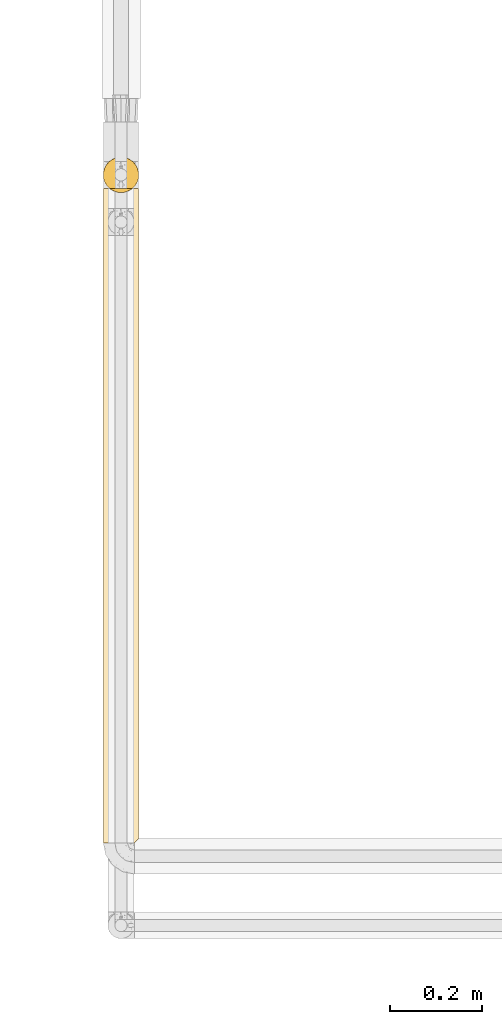
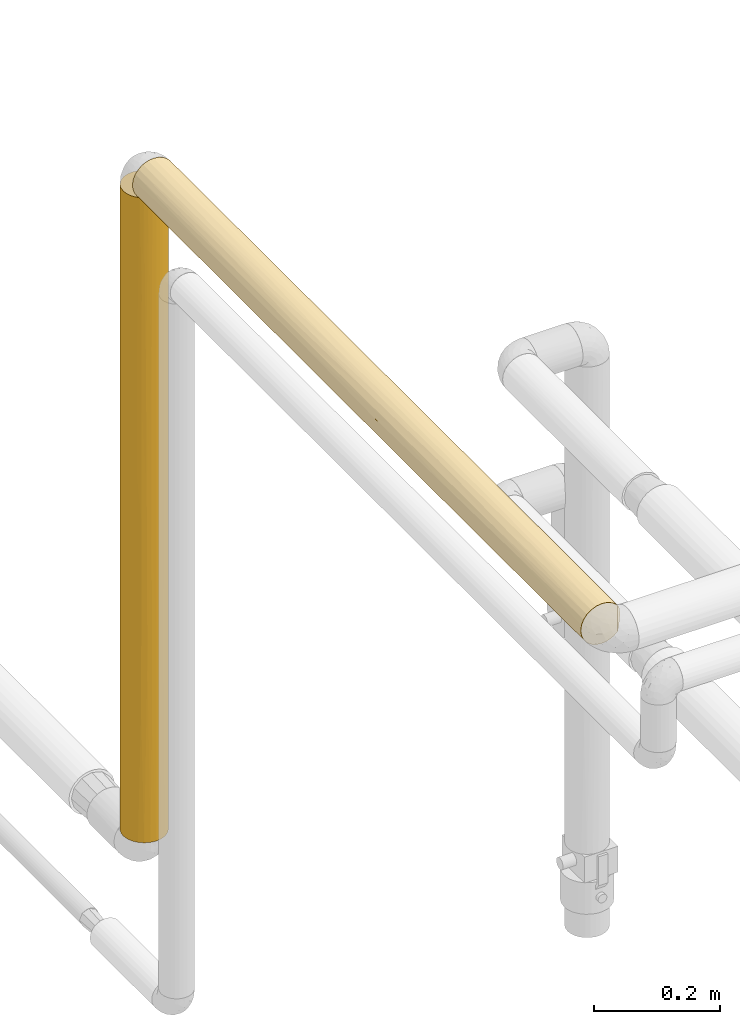
# One storey, part 23 of 827: 2 coverings.
"""IFC2X3 building model written with IfcOpenShell, lengths in millimetres."""

import ifcopenshell
import ifcopenshell.guid

model = None  # the IFC model being written
_history = None  # IfcOwnerHistory: only IFC2X3 demands one
_inside = {}  # id of a spatial element -> (the spatial element, [elements in it])
_under = {}  # id of a project, library or spatial element -> (it, [spatial elements below it])
_declared = {}  # id of a project -> (the project, [libraries it declares])
_typed = {}  # id of a type object -> (the type object, [elements of that type])
_made_of = {}  # id of a material, layer set ... -> (it, [elements and type objects made of it])


def new_model(schema):
    """Start an empty IFC model of exactly this schema.

    Asked for "IFC4X3", IfcOpenShell would pick the latest addendum, in which some entities
    have other attributes; the version numbers below select the first issue.
    IFC2X3 requires an IfcOwnerHistory on every rooted entity: one is made here for all.
    """
    global model, _history
    if schema == "IFC4X3":
        model = ifcopenshell.file(schema_version=(4, 3, 0, 0))
    else:
        model = ifcopenshell.file(schema=schema)
    _inside.clear()
    _under.clear()
    _declared.clear()
    _typed.clear()
    _made_of.clear()
    _history = None
    if model.schema == "IFC2X3":
        org = make("IfcOrganization", Name="unknown")
        user = make(
            "IfcPersonAndOrganization",
            ThePerson=make("IfcPerson", FamilyName="unknown"),
            TheOrganization=org,
        )
        app = make(
            "IfcApplication",
            ApplicationDeveloper=org,
            Version="unknown",
            ApplicationFullName="unknown",
            ApplicationIdentifier="unknown",
        )
        _history = make(
            "IfcOwnerHistory",
            OwningUser=user,
            OwningApplication=app,
            ChangeAction="ADDED",
            CreationDate=0,
        )
    return model


def make(cls, **values):
    """One entity of the class cls with the attributes given. An attribute that is None is left unset."""
    return model.create_entity(
        cls, **{name: value for name, value in values.items() if value is not None}
    )


def entity(cls, *values):
    """Any entity or typed value of the class cls, its attributes in the order of the schema. None: left unset."""
    e = model.create_entity(cls)
    for i, value in enumerate(values):
        if value is not None:
            e[i] = value
    return e


def rooted(cls, **values):
    """An entity with a GlobalId (a new one), such as an element, a storey or a relation."""
    return make(cls, GlobalId=ifcopenshell.guid.new(), OwnerHistory=_history, **values)


def si_unit(unit_type, name, prefix=None):
    """IfcSIUnit, for example si_unit("LENGTHUNIT", "METRE", prefix="MILLI")."""
    return make("IfcSIUnit", UnitType=unit_type, Prefix=prefix, Name=name)


def converted_unit(unit_type, name, factor, base, dimensions=None, offset=None):
    """IfcConversionBasedUnit, such as the inch: factor (a typed value) times the base unit."""
    return make(
        "IfcConversionBasedUnit"
        if offset is None
        else "IfcConversionBasedUnitWithOffset",
        ConversionOffset=offset,
        Dimensions=None
        if dimensions is None
        else entity("IfcDimensionalExponents", *dimensions),
        UnitType=unit_type,
        Name=name,
        ConversionFactor=make(
            "IfcMeasureWithUnit", ValueComponent=factor, UnitComponent=base
        ),
    )


def derived_unit(unit_type, elements):
    """IfcDerivedUnit: a product of units, each with its exponent."""
    return make(
        "IfcDerivedUnit",
        Elements=[
            make("IfcDerivedUnitElement", Unit=unit, Exponent=power)
            for unit, power in elements
        ],
        UnitType=unit_type,
    )


def assignment(units):
    """IfcUnitAssignment: the units of a project."""
    return None if units is None else make("IfcUnitAssignment", Units=units)


def point(xyz):
    """IfcCartesianPoint."""
    return None if xyz is None else make("IfcCartesianPoint", Coordinates=xyz)


def direction(xyz):
    """IfcDirection."""
    return None if xyz is None else make("IfcDirection", DirectionRatios=xyz)


def frame(location, z_axis=None, x_axis=None):
    """IfcAxis2Placement3D, a coordinate frame: its origin and axes. An axis left out is left unset."""
    return make(
        "IfcAxis2Placement3D",
        Location=point(location),
        Axis=direction(z_axis),
        RefDirection=direction(x_axis),
    )


def origin():
    """The frame at (0, 0, 0) with its axes left unset."""
    return frame((0.0, 0.0, 0.0))


def place(relative_to, where):
    """IfcLocalPlacement: puts the frame where relative to a parent placement (None: the world)."""
    return make(
        "IfcLocalPlacement", PlacementRelTo=relative_to, RelativePlacement=where
    )


def context(
    kind, dimensions, precision=None, world=None, true_north=None, identifier=None
):
    """IfcGeometricRepresentationContext, for example the 3D "Model" context."""
    return make(
        "IfcGeometricRepresentationContext",
        ContextIdentifier=identifier,
        ContextType=kind,
        CoordinateSpaceDimension=dimensions,
        Precision=precision,
        WorldCoordinateSystem=world,
        TrueNorth=true_north,
    )


def subcontext(parent, identifier, kind, view, scale=None):
    """IfcGeometricRepresentationSubContext, for example "Body" below "Model"."""
    return make(
        "IfcGeometricRepresentationSubContext",
        ContextIdentifier=identifier,
        ContextType=kind,
        ParentContext=parent,
        TargetScale=scale,
        TargetView=view,
    )


def project(units=None, contexts=None):
    """IfcProject with its units and contexts."""
    return rooted(
        "IfcProject",
        Name="project",
        RepresentationContexts=contexts,
        UnitsInContext=assignment(units),
    )


def spatial(cls, under=None, at=None, **own):
    """A site, building, storey or space (cls), placed at a placement, below another one or the project."""
    s = rooted(cls, ObjectPlacement=at, **own)
    if under is not None:
        _under.setdefault(under.id(), (under, []))[1].append(s)
    return s


def faces_of(points, faces, orient=None, outer=None):
    """IfcFace entities. A face is a list of loops; a loop is a list of indices into points, from 0.

    orient and outer hold one flag for each loop. By default every Orientation is true, the
    first loop of a face is its IfcFaceOuterBound and the others are IfcFaceBound.
    """
    made = []
    for i, loops in enumerate(faces):
        bounds = []
        for j, loop in enumerate(loops):
            is_outer = j == 0 if outer is None else outer[i][j]
            bounds.append(
                make(
                    "IfcFaceOuterBound" if is_outer else "IfcFaceBound",
                    Bound=make("IfcPolyLoop", Polygon=[points[k] for k in loop]),
                    Orientation=True if orient is None else orient[i][j],
                )
            )
        made.append(make("IfcFace", Bounds=bounds))
    return made


def faceted_brep(points, faces, orient=None, outer=None, voids=None):
    """IfcFacetedBrep: a solid bounded by flat faces; with voids (closed shells), ...WithVoids."""
    shared = [point(p) for p in points]
    hull = make("IfcClosedShell", CfsFaces=faces_of(shared, faces, orient, outer))
    if voids is None:
        return make("IfcFacetedBrep", Outer=hull)
    return make(
        "IfcFacetedBrepWithVoids",
        Outer=hull,
        Voids=[
            make(cls, CfsFaces=faces_of(shared, fs, o, b)) for cls, fs, o, b in voids
        ],
    )


def shape(context_of_items, identifier, shape_type, items):
    """IfcShapeRepresentation: the items that make up one representation, for example the "Body"."""
    return make(
        "IfcShapeRepresentation",
        ContextOfItems=context_of_items,
        RepresentationIdentifier=identifier,
        RepresentationType=shape_type,
        Items=items,
    )


def made_of(thing, what):
    """Note that an element or type object is made of a material, layer set ...; save() writes the relation."""
    if what is not None:
        _made_of.setdefault(what.id(), (what, []))[1].append(thing)
    return thing


def element(
    cls,
    number,
    at=None,
    inside=None,
    cuts=None,
    type_object=None,
    material=None,
    context=None,
    identifier="Body",
    shape_type=None,
    held_by="IfcProductDefinitionShape",
    body=None,
    shapes=None,
    **own,
):
    """One element of the class cls, such as IfcWall. Its Tag is "e" and its number.

    at: its placement. inside: the storey or other place that contains it. cuts: it is an
    opening in that element (IfcRelVoidsElement). A single representation is given by context,
    identifier, shape_type and body (its items); several are given by shapes. held_by: the class
    of the entity that holds the representations. save() writes the other relations.
    """
    e = rooted(cls, Tag="e%d" % number, ObjectPlacement=at, **own)
    if body is not None:
        shapes = [shape(context, identifier, shape_type, body)]
    if shapes is not None:
        e.Representation = make(held_by, Representations=shapes)
    if inside is not None:
        _inside.setdefault(inside.id(), (inside, []))[1].append(e)
    if cuts is not None:
        rooted(
            "IfcRelVoidsElement", RelatingBuildingElement=cuts, RelatedOpeningElement=e
        )
    if type_object is not None:
        _typed.setdefault(type_object.id(), (type_object, []))[1].append(e)
    return made_of(e, material)


def aggregate(whole, parts):
    """IfcRelAggregates: a whole, such as a stair, and the parts it consists of."""
    return rooted("IfcRelAggregates", RelatingObject=whole, RelatedObjects=parts)


def save(model, path):
    """Write the relations noted so far, then the file.

    IfcRelAggregates (storeys below a building ...), IfcRelContainedInSpatialStructure (elements
    in a storey), IfcRelDefinesByType, IfcRelAssociatesMaterial and IfcRelDeclares: one each for
    every whole, place, type object, material and project.
    """
    for whole, parts in _under.values():
        aggregate(whole, parts)
    for where, things in _inside.values():
        rooted(
            "IfcRelContainedInSpatialStructure",
            RelatedElements=things,
            RelatingStructure=where,
        )
    for kind, things in _typed.values():
        rooted("IfcRelDefinesByType", RelatedObjects=things, RelatingType=kind)
    for what, things in _made_of.values():
        rooted("IfcRelAssociatesMaterial", RelatedObjects=things, RelatingMaterial=what)
    for by, libraries in _declared.values():
        rooted("IfcRelDeclares", RelatingContext=by, RelatedDefinitions=libraries)
    model.write(path)


model = new_model("IFC2X3")

# Units and contexts
model_context = context("Model", 3, precision=0.01, world=origin(), true_north=direction((6.12303176911189e-17, 1.0)))
body_context = subcontext(model_context, "Body", "Model", "MODEL_VIEW")
ifc_project = project(units=[si_unit("LENGTHUNIT", "METRE", prefix="MILLI"), si_unit("AREAUNIT", "SQUARE_METRE"), si_unit("VOLUMEUNIT", "CUBIC_METRE"), converted_unit("PLANEANGLEUNIT", "DEGREE", entity("IfcRatioMeasure", 0.0174532925199433), si_unit("PLANEANGLEUNIT", "RADIAN"), dimensions=[0, 0, 0, 0, 0, 0, 0]), si_unit("MASSUNIT", "GRAM", prefix="KILO"), derived_unit("MASSDENSITYUNIT", [(si_unit("MASSUNIT", "GRAM", prefix="KILO"), 1), (si_unit("LENGTHUNIT", "METRE"), -3)]), derived_unit("MOMENTOFINERTIAUNIT", [(si_unit("LENGTHUNIT", "METRE"), 4)]), si_unit("TIMEUNIT", "SECOND"), si_unit("FREQUENCYUNIT", "HERTZ"), si_unit("THERMODYNAMICTEMPERATUREUNIT", "DEGREE_CELSIUS"), derived_unit("THERMALTRANSMITTANCEUNIT", [(si_unit("MASSUNIT", "GRAM", prefix="KILO"), 1), (si_unit("THERMODYNAMICTEMPERATUREUNIT", "KELVIN"), -1), (si_unit("TIMEUNIT", "SECOND"), -3)]), derived_unit("VOLUMETRICFLOWRATEUNIT", [(si_unit("LENGTHUNIT", "METRE"), 3), (si_unit("TIMEUNIT", "SECOND"), -1)]), derived_unit("MASSFLOWRATEUNIT", [(si_unit("MASSUNIT", "GRAM", prefix="KILO"), 1), (si_unit("TIMEUNIT", "SECOND"), -1)]), derived_unit("ROTATIONALFREQUENCYUNIT", [(si_unit("TIMEUNIT", "SECOND"), -1)]), si_unit("ELECTRICCURRENTUNIT", "AMPERE"), si_unit("ELECTRICVOLTAGEUNIT", "VOLT"), si_unit("POWERUNIT", "WATT"), si_unit("FORCEUNIT", "NEWTON", prefix="KILO"), si_unit("ILLUMINANCEUNIT", "LUX"), si_unit("LUMINOUSFLUXUNIT", "LUMEN"), si_unit("LUMINOUSINTENSITYUNIT", "CANDELA"), derived_unit("USERDEFINED", [(si_unit("MASSUNIT", "GRAM", prefix="KILO"), -1), (si_unit("LENGTHUNIT", "METRE"), -2), (si_unit("TIMEUNIT", "SECOND"), 3), (si_unit("LUMINOUSFLUXUNIT", "LUMEN"), 1)]), derived_unit("LINEARVELOCITYUNIT", [(si_unit("LENGTHUNIT", "METRE"), 1), (si_unit("TIMEUNIT", "SECOND"), -1)]), si_unit("PRESSUREUNIT", "PASCAL"), derived_unit("USERDEFINED", [(si_unit("LENGTHUNIT", "METRE"), -2), (si_unit("MASSUNIT", "GRAM", prefix="KILO"), 1), (si_unit("TIMEUNIT", "SECOND"), -2)]), derived_unit("LINEARFORCEUNIT", [(si_unit("MASSUNIT", "GRAM", prefix="KILO"), 1), (si_unit("LENGTHUNIT", "METRE"), 1), (si_unit("TIMEUNIT", "SECOND"), -2), (si_unit("LENGTHUNIT", "METRE"), -1)]), derived_unit("PLANARFORCEUNIT", [(si_unit("MASSUNIT", "GRAM", prefix="KILO"), 1), (si_unit("LENGTHUNIT", "METRE"), 1), (si_unit("TIMEUNIT", "SECOND"), -2), (si_unit("LENGTHUNIT", "METRE"), -2)])], contexts=[model_context])

# Site, building, storey
site_placement = place(None, origin())
site = spatial("IfcSite", under=ifc_project, at=site_placement, CompositionType="ELEMENT")
building_placement = place(site_placement, origin())
building = spatial("IfcBuilding", under=site, at=building_placement, CompositionType="ELEMENT")
storey_placement = place(building_placement, frame((0.0, 0.0, 28200.0)))
storey = spatial("IfcBuildingStorey", under=building, at=storey_placement, Name="08", CompositionType="ELEMENT", Elevation=28200.0)

# Coverings
covering_1_placement = place(storey_placement, frame((11891.91, 11180.3, 1573.25)))
element("IfcCovering", 1, at=covering_1_placement, inside=storey, Name=":ADSK_", ObjectType=":ADSK_", PredefinedType="INSULATION", context=body_context, shape_type="Brep", body=[
    faceted_brep([(74.9, 23.98, 1247.65), (77.51, 31.79, 1247.65), (78.4, 40.0, 1247.65), (77.09, 49.93, 1247.65), (73.25, 59.2, 1247.65), (67.15, 67.15, 1247.65), (59.2, 73.25, 1247.65), (49.93, 77.09, 1247.65), (40.0, 78.4, 1247.65), (30.06, 77.09, 1247.65), (20.8, 73.25, 1247.65), (12.84, 67.15, 1247.65), (6.74, 59.2, 1247.65), (2.9, 49.93, 1247.65), (1.6, 40.0, 1247.65), (2.48, 31.79, 1247.65), (5.09, 23.98, 1247.65), (9.31, 16.91, 1247.65), (14.94, 10.9, 1247.65), (65.05, 10.9, 1247.65), (70.68, 16.91, 1247.65), (78.4, 40.0, 1.6), (77.09, 30.06, 1.6), (73.25, 20.8, 1.6), (67.15, 12.84, 1.6), (59.2, 6.74, 1.6), (49.94, 2.9, 1.6), (40.0, 1.6, 1.6), (30.06, 2.9, 1.6), (20.8, 6.74, 1.6), (12.85, 12.84, 1.6), (6.74, 20.8, 1.6), (2.91, 30.06, 1.6), (1.6, 40.0, 1.6), (2.48, 48.2, 1.6), (5.1, 56.01, 1.6), (9.31, 63.08, 1.6), (14.94, 69.1, 1.6), (65.05, 69.1, 1.6), (70.68, 63.08, 1.6), (74.9, 56.01, 1.6), (77.51, 48.2, 1.6), (2.19, 33.3, 229.23), (16.85, 9.35, 847.96), (17.52, 8.86, 1058.28), (11.96, 13.75, 972.32), (4.52, 25.3, 173.67), (9.53, 16.62, 279.37), (4.52, 25.3, 398.59), (16.62, 9.53, 253.79), (1.6, 40.0, 1031.28), (3.58, 27.82, 972.33), (7.01, 20.33, 789.58), (7.01, 20.33, 1034.05), (31.81, 2.48, 598.39), (40.0, 1.6, 805.6), (31.85, 2.47, 913.79), (8.22, 18.43, 534.56), (3.17, 29.12, 674.9), (26.63, 4.0, 1240.75), (20.48, 6.92, 1243.68), (23.33, 5.4, 906.13), (40.0, 1.6, 1021.98), (40.0, 1.6, 1238.35), (33.21, 2.2, 1238.95), (25.3, 4.52, 351.9), (24.29, 4.96, 668.85), (1.6, 40.0, 382.16), (2.32, 32.59, 455.16), (40.0, 1.6, 372.86), (40.0, 1.6, 589.23), (11.62, 14.12, 710.66), (32.71, 2.29, 239.1), (17.27, 9.04, 621.65), (1.6, 40.0, 814.9), (1.6, 40.0, 598.53), (1.6, 40.0, 217.96), (1.6, 40.0, 650.72), (1.6, 40.0, 434.34), (1.6, 40.0, 867.09), (70.46, 16.62, 279.37), (63.37, 9.53, 253.79), (71.77, 18.43, 534.56), (68.37, 14.12, 710.66), (62.72, 9.04, 621.65), (47.29, 2.29, 239.1), (54.69, 4.52, 351.9), (59.51, 6.92, 1243.68), (62.29, 8.73, 1035.6), (56.66, 5.4, 906.13), (48.14, 2.47, 913.79), (48.18, 2.48, 598.39), (75.47, 25.3, 173.67), (62.38, 8.79, 828.46), (68.03, 13.75, 972.32), (53.36, 4.0, 1240.75), (77.81, 33.3, 229.23), (78.4, 40.0, 217.97), (78.4, 40.0, 382.16), (76.83, 29.12, 674.9), (77.68, 32.59, 455.16), (78.4, 40.0, 598.53), (75.47, 25.3, 398.59), (46.78, 2.2, 1238.95), (76.41, 27.82, 972.33), (78.4, 40.0, 1031.28), (72.98, 20.33, 1034.05), (72.98, 20.33, 789.58), (55.84, 5.02, 582.55), (78.4, 40.0, 814.91), (78.4, 40.0, 650.71), (78.4, 40.0, 434.34), (78.4, 40.0, 867.09), (76.83, 50.87, 574.34), (76.42, 52.17, 276.92), (72.98, 59.66, 459.66), (62.72, 70.95, 627.59), (56.37, 74.73, 369.4), (51.95, 76.49, 536.46), (46.79, 77.79, 10.29), (40.0, 78.4, 227.27), (50.19, 77.02, 266.4), (75.47, 54.69, 850.66), (75.47, 54.69, 1075.58), (77.81, 46.69, 1020.01), (77.67, 47.4, 794.09), (72.98, 59.66, 215.2), (68.71, 65.49, 576.68), (68.71, 65.5, 337.43), (62.54, 71.08, 307.84), (53.36, 76.0, 8.5), (59.51, 73.07, 5.57), (70.46, 63.37, 969.88), (47.1, 77.73, 783.87), (40.0, 78.4, 629.27), (40.0, 78.4, 660.01), (40.0, 78.4, 876.39), (40.0, 78.4, 938.46), (63.37, 70.46, 995.46), (40.0, 78.4, 443.64), (54.69, 75.47, 901.8), (47.66, 77.62, 1020.33), (71.92, 61.33, 750.68), (66.93, 67.37, 796.32), (40.0, 78.4, 10.9), (11.97, 66.24, 276.93), (16.85, 70.64, 401.29), (17.52, 71.13, 190.97), (9.53, 63.37, 969.88), (7.01, 59.66, 215.2), (16.62, 70.46, 995.46), (33.21, 77.79, 10.29), (26.64, 76.0, 8.5), (31.85, 77.52, 335.45), (20.48, 73.07, 5.57), (17.27, 70.95, 627.59), (24.29, 75.04, 580.4), (3.58, 52.17, 276.92), (32.71, 77.7, 1010.14), (2.18, 46.69, 1020.01), (8.22, 61.56, 714.69), (11.62, 65.87, 538.58), (7.01, 59.66, 459.66), (23.34, 74.59, 343.11), (25.3, 75.47, 897.34), (4.52, 54.69, 1075.58), (3.17, 50.87, 574.34), (4.52, 54.69, 850.66), (31.81, 77.51, 650.85), (2.32, 47.4, 794.09)], [[[0, 1, 2, 3, 4, 5, 6, 7, 8, 9, 10, 11, 12, 13, 14, 15, 16, 17, 18, 19, 20]], [[21, 22, 23, 24, 25, 26, 27, 28, 29, 30, 31, 32, 33, 34, 35, 36, 37, 38, 39, 40, 41]], [[33, 32, 42]], [[43, 44, 45]], [[46, 47, 48]], [[47, 30, 49]], [[15, 50, 51]], [[51, 52, 53]], [[54, 55, 56]], [[47, 57, 48]], [[52, 51, 58]], [[31, 46, 32]], [[59, 60, 61]], [[62, 63, 64]], [[17, 16, 53]], [[65, 54, 66]], [[17, 53, 45]], [[67, 42, 68]], [[54, 69, 70, 55]], [[64, 56, 62]], [[57, 71, 52]], [[31, 30, 47]], [[17, 45, 18]], [[28, 65, 29]], [[69, 72, 27]], [[64, 59, 56]], [[44, 60, 18]], [[51, 16, 15]], [[28, 72, 65]], [[49, 73, 47]], [[43, 73, 66]], [[32, 46, 42]], [[65, 66, 73]], [[58, 48, 57]], [[56, 59, 61]], [[55, 62, 56]], [[43, 66, 61]], [[66, 56, 61]], [[54, 65, 72]], [[30, 29, 49]], [[57, 52, 58]], [[51, 53, 16]], [[45, 53, 52]], [[51, 74, 58]], [[58, 75, 68]], [[29, 65, 49]], [[73, 49, 65]], [[47, 73, 57]], [[71, 57, 73]], [[43, 71, 73]], [[45, 52, 71]], [[47, 46, 31]], [[48, 68, 42]], [[48, 42, 46]], [[42, 67, 76, 33]], [[48, 58, 68]], [[27, 72, 28]], [[58, 74, 77, 75]], [[68, 75, 78, 67]], [[54, 72, 69]], [[44, 61, 60]], [[71, 43, 45]], [[45, 44, 18]], [[61, 44, 43]], [[50, 15, 14]], [[51, 50, 79, 74]], [[56, 66, 54]], [[24, 80, 81]], [[82, 83, 84]], [[85, 27, 26]], [[85, 26, 86]], [[19, 87, 88]], [[87, 89, 88]], [[25, 86, 26]], [[89, 90, 91]], [[92, 80, 23]], [[90, 62, 55]], [[25, 24, 81]], [[93, 83, 94]], [[95, 89, 87]], [[22, 92, 23]], [[96, 21, 97, 98]], [[99, 100, 101]], [[102, 82, 80]], [[69, 85, 91]], [[102, 92, 96]], [[62, 90, 103]], [[19, 94, 20]], [[23, 80, 24]], [[0, 104, 1]], [[105, 1, 104]], [[20, 106, 0]], [[0, 106, 104]], [[95, 103, 90]], [[107, 106, 94]], [[108, 89, 91]], [[99, 104, 107]], [[107, 82, 99]], [[105, 2, 1]], [[103, 63, 62]], [[91, 90, 55]], [[90, 89, 95]], [[91, 55, 70, 69]], [[91, 86, 108]], [[102, 99, 82]], [[81, 84, 86]], [[94, 106, 20]], [[104, 106, 107]], [[100, 102, 96]], [[109, 104, 99]], [[84, 81, 80]], [[86, 25, 81]], [[83, 82, 107]], [[84, 80, 82]], [[107, 94, 83]], [[93, 94, 88]], [[96, 92, 22]], [[80, 92, 102]], [[21, 96, 22]], [[96, 98, 100]], [[99, 101, 110, 109]], [[99, 102, 100]], [[100, 98, 111, 101]], [[91, 85, 86]], [[27, 85, 69]], [[93, 88, 89]], [[19, 88, 94]], [[108, 93, 89]], [[83, 93, 84]], [[104, 109, 112, 105]], [[86, 84, 108]], [[108, 84, 93]], [[113, 114, 115]], [[116, 117, 118]], [[119, 120, 121]], [[122, 123, 124]], [[113, 125, 110]], [[3, 123, 4]], [[97, 41, 114]], [[126, 40, 39]], [[40, 126, 114]], [[127, 115, 128]], [[129, 128, 38]], [[124, 2, 105, 112]], [[128, 115, 126]], [[117, 121, 118]], [[130, 117, 131]], [[123, 132, 4]], [[133, 134, 135, 136, 137]], [[6, 5, 138]], [[118, 121, 139]], [[121, 130, 119]], [[40, 114, 41]], [[140, 116, 118]], [[129, 117, 116]], [[6, 140, 7]], [[118, 139, 134]], [[141, 140, 133]], [[130, 121, 117]], [[131, 129, 38]], [[127, 128, 129]], [[4, 132, 5]], [[5, 132, 138]], [[125, 122, 124]], [[115, 142, 113]], [[97, 21, 41]], [[142, 115, 127]], [[138, 116, 140]], [[39, 38, 128]], [[114, 126, 115]], [[133, 118, 134]], [[7, 141, 8]], [[111, 114, 113]], [[138, 132, 143]], [[140, 6, 138]], [[39, 128, 126]], [[127, 129, 116]], [[116, 143, 127]], [[127, 143, 142]], [[138, 143, 116]], [[142, 143, 132]], [[132, 122, 142]], [[142, 122, 113]], [[141, 133, 137]], [[118, 133, 140]], [[8, 141, 137]], [[140, 141, 7]], [[124, 123, 3]], [[132, 123, 122]], [[2, 124, 3]], [[124, 112, 125]], [[113, 110, 101, 111]], [[113, 122, 125]], [[125, 112, 109, 110]], [[120, 119, 144]], [[120, 139, 121]], [[131, 117, 129]], [[114, 111, 98, 97]], [[145, 146, 147]], [[12, 11, 148]], [[149, 36, 35]], [[148, 11, 150]], [[151, 152, 153]], [[37, 147, 154]], [[151, 153, 120]], [[146, 155, 156]], [[34, 76, 157]], [[36, 149, 145]], [[158, 8, 137, 136]], [[14, 13, 159]], [[155, 148, 150]], [[160, 161, 162]], [[152, 154, 163]], [[9, 158, 164]], [[13, 12, 165]], [[162, 157, 166]], [[13, 165, 159]], [[167, 148, 160]], [[157, 35, 34]], [[148, 167, 165]], [[164, 168, 156]], [[36, 145, 37]], [[149, 157, 162]], [[79, 159, 169]], [[120, 144, 151]], [[164, 10, 9]], [[168, 136, 135, 134, 139]], [[168, 139, 153]], [[164, 156, 155]], [[166, 167, 160]], [[153, 152, 163]], [[139, 120, 153]], [[146, 156, 163]], [[156, 153, 163]], [[168, 164, 158]], [[11, 10, 150]], [[160, 162, 166]], [[157, 149, 35]], [[145, 149, 162]], [[157, 78, 166]], [[166, 77, 169]], [[10, 164, 150]], [[155, 150, 164]], [[148, 155, 160]], [[161, 160, 155]], [[146, 161, 155]], [[145, 162, 161]], [[148, 165, 12]], [[167, 169, 159]], [[167, 159, 165]], [[159, 79, 50, 14]], [[167, 166, 169]], [[8, 158, 9]], [[166, 78, 75, 77]], [[169, 77, 74, 79]], [[168, 158, 136]], [[147, 163, 154]], [[161, 146, 145]], [[145, 147, 37]], [[163, 147, 146]], [[76, 34, 33]], [[157, 76, 67, 78]], [[153, 156, 168]], [[60, 59, 64, 63, 103, 95, 87, 19, 18]], [[154, 152, 151, 144, 119, 130, 131, 38, 37]]]),
])
covering_2_placement = place(storey_placement, frame((11891.91, 9770.3, 2810.01)))
element("IfcCovering", 2, at=covering_2_placement, inside=storey, Name=":ADSK_", ObjectType=":ADSK_", PredefinedType="INSULATION", context=body_context, shape_type="Brep", body=[
    faceted_brep([(20.8, 1.6, 6.74), (30.06, 1.6, 2.9), (40.0, 1.6, 1.6), (48.2, 1.6, 2.48), (56.01, 1.6, 5.09), (63.08, 1.6, 9.31), (69.1, 1.6, 14.94), (69.1, 1.6, 65.05), (63.08, 1.6, 70.68), (56.01, 1.6, 74.9), (48.2, 1.6, 77.51), (40.0, 1.6, 78.4), (30.06, 1.6, 77.09), (20.8, 1.6, 73.25), (12.84, 1.6, 67.15), (6.74, 1.6, 59.2), (2.9, 1.6, 49.93), (1.6, 1.6, 40.0), (2.9, 1.6, 30.06), (6.74, 1.6, 20.8), (12.84, 1.6, 12.84), (65.05, 1420.9, 10.9), (14.94, 1420.9, 10.9), (9.31, 1420.9, 16.91), (5.09, 1420.9, 23.98), (2.48, 1420.9, 31.79), (1.6, 1420.9, 40.0), (2.9, 1420.9, 49.93), (6.74, 1420.9, 59.2), (12.84, 1420.9, 67.15), (20.8, 1420.9, 73.25), (30.06, 1420.9, 77.09), (40.0, 1420.9, 78.4), (49.93, 1420.9, 77.09), (59.2, 1420.9, 73.25), (67.15, 1420.9, 67.15), (73.25, 1420.9, 59.2), (77.09, 1420.9, 49.93), (78.4, 1420.9, 40.0), (77.51, 1420.9, 31.79), (74.9, 1420.9, 23.98), (70.68, 1420.9, 16.91), (2.86, 805.97, 30.24), (1.6, 988.15, 40.0), (3.58, 1135.65, 27.82), (1.6, 217.97, 40.0), (16.62, 254.84, 9.53), (1.6, 1204.52, 40.0), (9.53, 289.28, 16.62), (7.01, 1203.92, 20.33), (11.96, 1135.64, 13.75), (29.48, 733.77, 3.06), (23.32, 1038.95, 5.41), (31.76, 1087.04, 2.49), (17.68, 480.31, 8.74), (25.3, 390.98, 4.52), (4.52, 191.33, 25.3), (2.43, 542.57, 32.02), (2.38, 310.69, 32.28), (1.6, 555.4, 40.0), (26.63, 1414.0, 4.0), (33.21, 1412.2, 2.2), (7.01, 938.27, 20.33), (40.0, 1195.22, 1.6), (25.3, 169.35, 4.52), (32.17, 280.16, 2.4), (12.25, 879.45, 13.45), (17.51, 1228.58, 8.86), (4.52, 430.05, 25.3), (9.18, 623.33, 17.08), (16.78, 1015.91, 9.4), (40.0, 217.97, 1.6), (22.59, 824.32, 5.77), (23.3, 609.64, 5.41), (20.48, 1416.92, 6.92), (40.0, 978.85, 1.6), (17.22, 708.38, 9.08), (40.0, 1411.6, 1.6), (31.85, 512.34, 2.47), (40.0, 762.48, 1.6), (5.06, 663.8, 24.05), (1.6, 771.78, 40.0), (40.0, 546.1, 1.6), (40.0, 273.85, 1.6), (68.03, 1156.9, 13.75), (52.17, 377.97, 3.58), (59.52, 244.6, 6.93), (76.41, 1156.9, 27.82), (76.85, 842.76, 29.21), (72.98, 991.73, 20.33), (76.0, 8.5, 26.63), (77.01, 311.49, 29.79), (77.79, 10.29, 33.21), (59.18, 495.3, 6.73), (56.89, 681.89, 5.51), (62.77, 713.69, 9.08), (72.98, 1222.78, 20.33), (46.78, 1412.2, 2.2), (48.22, 1087.04, 2.49), (78.4, 227.27, 40.0), (78.4, 10.9, 40.0), (50.61, 734.48, 3.09), (59.51, 1416.92, 6.92), (62.47, 1235.68, 8.86), (53.36, 1414.0, 4.0), (77.54, 569.76, 31.93), (74.54, 556.66, 23.23), (67.85, 892.26, 13.56), (69.43, 621.16, 15.33), (78.4, 876.39, 40.0), (66.24, 359.61, 11.96), (73.28, 286.5, 20.84), (73.07, 5.57, 20.48), (63.28, 1029.73, 9.46), (78.4, 443.64, 40.0), (72.99, 763.92, 20.35), (78.4, 1204.52, 40.0), (56.67, 1041.45, 5.41), (78.4, 660.01, 40.0), (63.37, 1133.21, 70.46), (70.46, 1167.65, 63.37), (70.59, 406.58, 63.21), (70.91, 714.11, 62.77), (66.54, 543.04, 67.74), (75.47, 1253.14, 54.69), (77.59, 1142.33, 47.82), (71.13, 193.91, 62.48), (73.07, 5.57, 59.51), (74.58, 383.54, 56.68), (76.0, 8.5, 53.36), (54.69, 1231.16, 75.47), (77.5, 335.45, 48.23), (77.79, 10.29, 46.78), (66.24, 286.85, 68.03), (52.17, 286.84, 76.41), (40.0, 217.97, 78.4), (76.93, 688.72, 50.51), (54.69, 992.44, 75.47), (62.91, 799.16, 70.81), (47.71, 1111.8, 77.61), (71.25, 942.18, 62.31), (75.47, 1031.51, 54.69), (47.98, 879.92, 77.56), (59.66, 218.57, 72.98), (59.66, 484.22, 72.98), (49.75, 616.52, 77.14), (40.0, 434.34, 78.4), (74.23, 598.17, 57.4), (74.58, 812.85, 56.69), (40.0, 867.09, 78.4), (77.52, 910.15, 48.14), (55.94, 758.69, 74.93), (40.0, 650.71, 78.4), (40.0, 1204.52, 78.4), (16.62, 1161.7, 70.46), (9.53, 1096.62, 63.37), (31.95, 630.11, 77.54), (32.74, 326.15, 77.7), (27.12, 195.31, 76.17), (4.52, 1175.84, 54.69), (33.4, 1050.66, 77.82), (28.6, 1210.93, 76.66), (25.3, 1021.72, 75.47), (25.3, 400.77, 75.47), (9.53, 289.28, 63.37), (2.3, 477.21, 47.33), (2.81, 243.9, 49.58), (4.52, 430.05, 54.69), (19.81, 897.22, 72.66), (22.3, 1194.19, 74.08), (8.67, 856.8, 62.2), (9.09, 614.23, 62.79), (16.62, 711.25, 70.46), (2.29, 1096.34, 47.28), (4.52, 891.18, 54.69), (2.22, 859.25, 46.88), (3.46, 660.61, 51.81), (5.5, 214.59, 56.87), (16.62, 254.84, 70.46), (18.5, 483.04, 71.81), (23.98, 688.54, 74.9), (13.93, 936.47, 68.19), (29.31, 837.29, 76.88)], [[[0, 1, 2, 3, 4, 5, 6, 7, 8, 9, 10, 11, 12, 13, 14, 15, 16, 17, 18, 19, 20]], [[21, 22, 23, 24, 25, 26, 27, 28, 29, 30, 31, 32, 33, 34, 35, 36, 37, 38, 39, 40, 41]], [[42, 43, 44]], [[18, 17, 45]], [[0, 20, 46]], [[44, 47, 25]], [[19, 48, 20]], [[49, 24, 23]], [[50, 49, 23]], [[51, 52, 53]], [[54, 55, 46]], [[18, 56, 19]], [[57, 58, 59]], [[60, 61, 53]], [[49, 62, 44]], [[24, 44, 25]], [[63, 53, 61]], [[56, 48, 19]], [[1, 64, 65]], [[22, 50, 23]], [[50, 66, 62]], [[67, 60, 52]], [[68, 69, 48]], [[52, 70, 67]], [[1, 71, 2]], [[0, 64, 1]], [[48, 46, 20]], [[72, 51, 73]], [[67, 22, 74]], [[63, 75, 53]], [[70, 76, 66]], [[68, 58, 57]], [[42, 44, 62]], [[66, 69, 62]], [[61, 77, 63]], [[78, 51, 79]], [[53, 52, 60]], [[55, 78, 65]], [[51, 78, 73]], [[68, 80, 69]], [[76, 73, 54]], [[62, 69, 80]], [[57, 81, 42]], [[47, 44, 43]], [[58, 68, 56]], [[65, 82, 83, 71]], [[47, 26, 25]], [[69, 76, 54]], [[48, 69, 54]], [[64, 46, 55]], [[58, 18, 45]], [[48, 56, 68]], [[18, 58, 56]], [[59, 58, 45]], [[57, 80, 68]], [[80, 57, 42]], [[70, 66, 50]], [[69, 66, 76]], [[50, 22, 67]], [[70, 52, 72]], [[67, 74, 60]], [[50, 67, 70]], [[62, 49, 50]], [[24, 49, 44]], [[46, 64, 0]], [[65, 64, 55]], [[73, 78, 55]], [[1, 65, 71]], [[51, 75, 79]], [[82, 65, 78]], [[75, 51, 53]], [[82, 78, 79]], [[72, 73, 76]], [[55, 54, 73]], [[54, 46, 48]], [[70, 72, 76]], [[51, 72, 52]], [[81, 57, 59]], [[81, 43, 42]], [[62, 80, 42]], [[84, 21, 41]], [[4, 85, 86]], [[87, 88, 89]], [[90, 91, 92]], [[93, 94, 95]], [[40, 96, 41]], [[97, 98, 63]], [[99, 100, 92]], [[4, 86, 5]], [[3, 83, 85]], [[99, 92, 91]], [[75, 98, 101]], [[93, 86, 85]], [[102, 103, 104]], [[97, 104, 98]], [[105, 91, 106]], [[107, 84, 89]], [[107, 108, 95]], [[87, 109, 88]], [[101, 82, 79, 75]], [[110, 86, 93]], [[111, 90, 112]], [[113, 84, 107]], [[6, 5, 110]], [[113, 103, 84]], [[96, 84, 41]], [[111, 6, 110]], [[114, 91, 105]], [[91, 90, 111]], [[39, 87, 40]], [[107, 89, 115]], [[3, 85, 4]], [[111, 106, 91]], [[63, 77, 97]], [[89, 96, 87]], [[39, 38, 116]], [[103, 102, 21]], [[39, 116, 87]], [[109, 87, 116]], [[98, 104, 117]], [[75, 63, 98]], [[98, 117, 101]], [[94, 117, 95]], [[82, 101, 85]], [[88, 118, 105]], [[115, 88, 106]], [[87, 96, 40]], [[84, 96, 89]], [[108, 115, 106]], [[113, 95, 117]], [[111, 108, 106]], [[110, 95, 108]], [[6, 111, 112]], [[108, 111, 110]], [[95, 113, 107]], [[117, 104, 103]], [[84, 103, 21]], [[117, 103, 113]], [[106, 88, 105]], [[107, 115, 108]], [[118, 88, 109]], [[118, 114, 105]], [[88, 115, 89]], [[3, 2, 71, 83]], [[83, 82, 85]], [[5, 86, 110]], [[94, 85, 101]], [[110, 93, 95]], [[85, 94, 93]], [[117, 94, 101]], [[91, 114, 99]], [[35, 119, 120]], [[121, 122, 123]], [[37, 124, 125]], [[37, 116, 38]], [[126, 7, 127]], [[121, 126, 128]], [[36, 124, 37]], [[129, 128, 126]], [[130, 119, 34]], [[99, 131, 132]], [[36, 35, 120]], [[7, 133, 8]], [[131, 99, 114]], [[134, 135, 10]], [[136, 128, 131]], [[137, 138, 119]], [[139, 137, 130]], [[140, 141, 120]], [[137, 139, 142]], [[133, 143, 8]], [[133, 123, 144]], [[143, 9, 8]], [[9, 134, 10]], [[33, 130, 34]], [[145, 146, 134]], [[34, 119, 35]], [[129, 132, 131]], [[144, 134, 143]], [[147, 136, 148]], [[149, 142, 139]], [[145, 134, 144]], [[10, 135, 11]], [[132, 100, 99]], [[150, 136, 118]], [[131, 128, 129]], [[141, 150, 125]], [[136, 150, 148]], [[137, 151, 138]], [[122, 148, 140]], [[144, 138, 151]], [[142, 152, 145]], [[33, 32, 153]], [[123, 138, 144]], [[116, 125, 109]], [[146, 135, 134]], [[138, 122, 140]], [[119, 138, 140]], [[124, 120, 141]], [[139, 33, 153]], [[119, 130, 137]], [[33, 139, 130]], [[149, 139, 153]], [[142, 151, 137]], [[151, 142, 145]], [[121, 123, 133]], [[138, 123, 122]], [[133, 7, 126]], [[121, 128, 147]], [[126, 127, 129]], [[133, 126, 121]], [[144, 143, 133]], [[9, 143, 134]], [[120, 124, 36]], [[125, 124, 141]], [[148, 150, 141]], [[37, 125, 116]], [[136, 114, 118]], [[109, 125, 150]], [[114, 136, 131]], [[109, 150, 118]], [[147, 148, 122]], [[141, 140, 148]], [[140, 120, 119]], [[121, 147, 122]], [[136, 147, 128]], [[152, 142, 149]], [[152, 146, 145]], [[144, 151, 145]], [[154, 29, 155]], [[156, 146, 152, 149]], [[12, 135, 157]], [[157, 158, 12]], [[155, 28, 159]], [[160, 161, 162]], [[27, 26, 47]], [[17, 16, 45]], [[156, 163, 157]], [[15, 14, 164]], [[165, 166, 167]], [[154, 168, 169]], [[170, 171, 172]], [[159, 173, 174]], [[175, 176, 174]], [[146, 157, 135]], [[177, 167, 166]], [[178, 164, 14]], [[28, 27, 159]], [[28, 155, 29]], [[164, 167, 177]], [[167, 164, 171]], [[164, 179, 171]], [[163, 156, 180]], [[31, 153, 32]], [[12, 11, 135]], [[29, 154, 30]], [[174, 173, 175]], [[168, 154, 181]], [[14, 13, 178]], [[178, 179, 164]], [[181, 154, 155]], [[160, 162, 182]], [[165, 167, 176]], [[169, 162, 161]], [[158, 178, 13]], [[179, 178, 163]], [[172, 181, 170]], [[176, 171, 174]], [[47, 173, 27]], [[155, 159, 174]], [[173, 47, 43]], [[173, 43, 175]], [[27, 173, 159]], [[176, 81, 59]], [[59, 165, 176]], [[175, 81, 176]], [[171, 176, 167]], [[59, 45, 165]], [[166, 45, 16]], [[45, 166, 165]], [[177, 16, 15]], [[16, 177, 166]], [[164, 177, 15]], [[175, 43, 81]], [[156, 157, 146]], [[157, 163, 158]], [[168, 182, 162]], [[168, 180, 182]], [[178, 158, 163]], [[13, 12, 158]], [[181, 155, 170]], [[168, 181, 172]], [[155, 174, 170]], [[174, 171, 170]], [[180, 168, 172]], [[168, 162, 169]], [[180, 172, 179]], [[180, 156, 182]], [[156, 149, 182]], [[160, 149, 153]], [[149, 160, 182]], [[161, 153, 31]], [[153, 161, 160]], [[30, 161, 31]], [[161, 30, 169]], [[30, 154, 169]], [[180, 179, 163]], [[171, 179, 172]], [[6, 112, 90, 92, 100, 132, 129, 127, 7]], [[102, 104, 97, 77, 61, 60, 74, 22, 21]]]),
])

save(model, "model.ifc")
